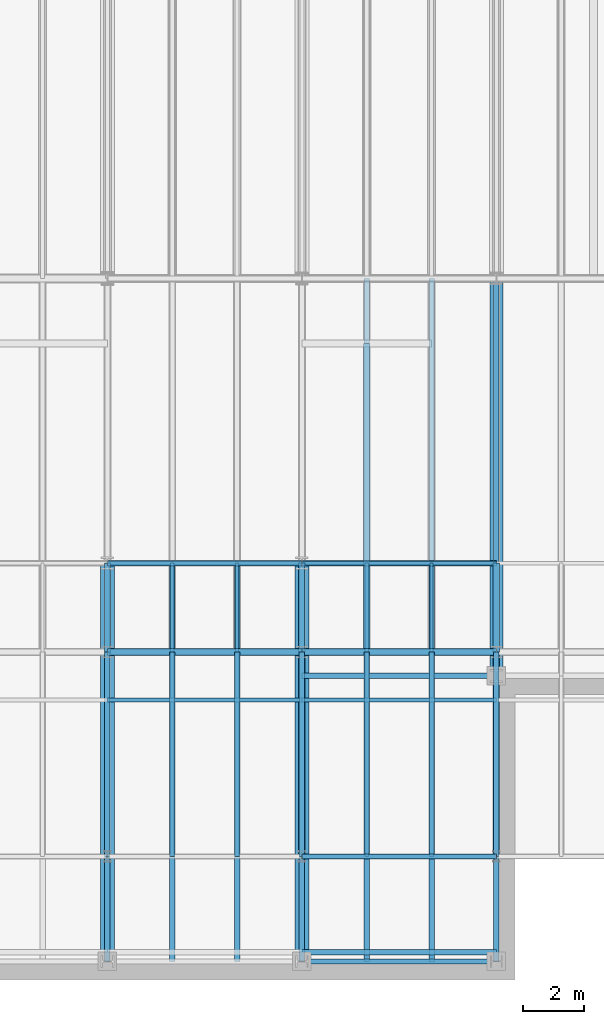
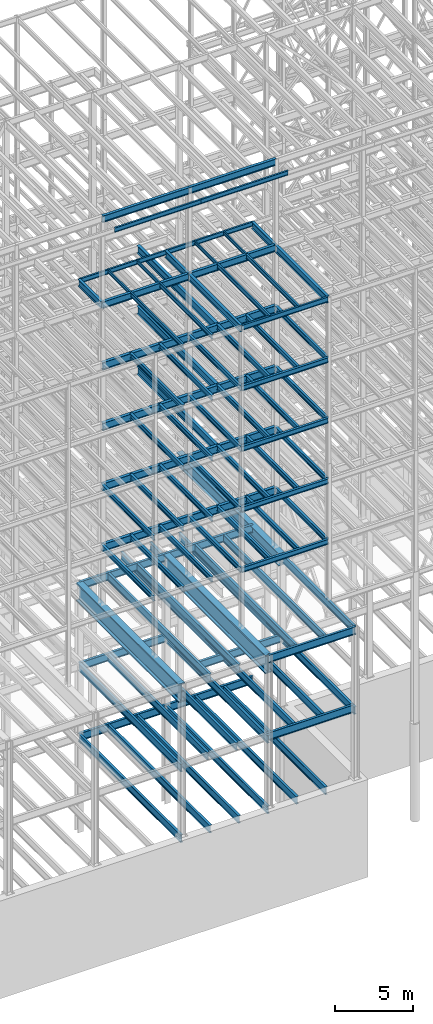
# One storey, part 129 of 150: 95 beams.
"""IFC2X3 building model written with IfcOpenShell, lengths in millimetres."""

from ifc_helpers import new_model, si_unit, frame, origin_with_axes, origin_2d_with_axis, place, context, subcontext, project, spatial, i_section, extrude, material, type_object, element, save


model = new_model("IFC2X3")

# Units and contexts
model_context = context("Model", 3, precision=1e-05, world=origin_with_axes())
body_context = subcontext(model_context, "Body", "Model", "MODEL_VIEW")
ifc_project = project(units=[si_unit("LENGTHUNIT", "METRE", prefix="MILLI"), si_unit("AREAUNIT", "SQUARE_METRE"), si_unit("VOLUMEUNIT", "CUBIC_METRE"), si_unit("MASSUNIT", "GRAM", prefix="KILO"), si_unit("TIMEUNIT", "SECOND"), si_unit("PLANEANGLEUNIT", "RADIAN"), si_unit("SOLIDANGLEUNIT", "STERADIAN"), si_unit("THERMODYNAMICTEMPERATUREUNIT", "DEGREE_CELSIUS"), si_unit("LUMINOUSINTENSITYUNIT", "LUMEN")], contexts=[model_context])

# Site, building, storey
site_placement = place(None, origin_with_axes())
site = spatial("IfcSite", under=ifc_project, at=site_placement, CompositionType="ELEMENT")
building_placement = place(site_placement, origin_with_axes())
building = spatial("IfcBuilding", under=site, at=building_placement, Name="Undefined", CompositionType="ELEMENT")
storey_placement = place(building_placement, origin_with_axes())
storey = spatial("IfcBuildingStorey", under=building, at=storey_placement, Name="Undefined", CompositionType="ELEMENT", Elevation=0.0)

# Beams
ifc_material = material(Name="STEEL/A992")
beam_type_1 = type_object("IfcBeamType", Name="W16X31", PredefinedType="NOTDEFINED")
beam_1_placement = place(storey_placement, frame((37388.8, 3454.4, 59005.7875), z_axis=(0.0, 0.0, 1.0), x_axis=(1.0, 0.0, 0.0)))
element("IfcBeam", 1, at=beam_1_placement, inside=storey, type_object=beam_type_1, material=ifc_material, Name="BEAM", ObjectType="W16X31", context=body_context, shape_type="SweptSolid", body=[
    extrude(i_section(OverallWidth=140.462, OverallDepth=403.225, WebThickness=6.3499, FlangeThickness=11.176, FilletRadius=17.399, at=origin_2d_with_axis()), frame((6400.80000000001, 0.0, 0.0), z_axis=(-1.0, 0.0, 0.0), x_axis=(0.0, -1.0, 0.0)), (0.0, 0.0, 1.0), 6400.8),
])
beam_type_2 = type_object("IfcBeamType", Name="W24X68", PredefinedType="NOTDEFINED")
beam_2_placement = place(storey_placement, frame((39522.4, 10185.4, 54181.375), z_axis=(0.0, 0.0, 1.0), x_axis=(0.0, 1.0, 0.0)))
element("IfcBeam", 2, at=beam_2_placement, inside=storey, type_object=beam_type_2, material=ifc_material, Name="BEAM", ObjectType="W24X68", context=body_context, shape_type="SweptSolid", body=[
    extrude(i_section(OverallWidth=227.838, OverallDepth=603.25, WebThickness=11.1125, FlangeThickness=14.859, FilletRadius=23.2409, at=origin_2d_with_axis()), frame((10159.9979680001, 0.0, 0.0), z_axis=(-1.0, 0.0, 0.0), x_axis=(0.0, -1.0, 0.0)), (0.0, 0.0, 1.0), 10159.9979680001),
])
for number, where, z_axis, x_axis, name in (
    (3, (37388.8, 10185.4, 54181.375), (0.0, 0.0, 1.0), (1.0, 0.0, 0.0), "BEAM"),
    (4, (30988.0, 10185.4, 54181.375), (0.0, 0.0, 1.0), (1.0, 0.0, 0.0), "BEAM"),
):
    element("IfcBeam", number, at=place(storey_placement, frame(where, z_axis=z_axis, x_axis=x_axis)), inside=storey, type_object=beam_type_2, material=ifc_material, Name=name, ObjectType="W24X68", context=body_context, shape_type="SweptSolid", body=[
        extrude(i_section(OverallWidth=227.838, OverallDepth=603.25, WebThickness=11.1125, FlangeThickness=14.859, FilletRadius=23.2409, at=origin_2d_with_axis()), frame((6400.79935992001, 0.0, 0.0), z_axis=(-1.0, 0.0, 0.0), x_axis=(0.0, -1.0, 0.0)), (0.0, 0.0, 1.0), 6400.79935992),
    ])
beam_3_placement = place(storey_placement, frame((39522.4, 10185.4, 49456.975), z_axis=(0.0, 0.0, 1.0), x_axis=(0.0, 1.0, 0.0)))
element("IfcBeam", 5, at=beam_3_placement, inside=storey, type_object=beam_type_2, material=ifc_material, Name="BEAM", ObjectType="W24X68", context=body_context, shape_type="SweptSolid", body=[
    extrude(i_section(OverallWidth=227.838, OverallDepth=603.25, WebThickness=11.1125, FlangeThickness=14.859, FilletRadius=23.2409, at=origin_2d_with_axis()), frame((10159.998984, 0.0, 0.0), z_axis=(-1.0, 0.0, 0.0), x_axis=(0.0, -1.0, 0.0)), (0.0, 0.0, 1.0), 10159.998984),
])
for number, where, z_axis, x_axis, name in (
    (6, (37388.8, 10185.4, 49456.975), (0.0, 0.0, 1.0), (1.0, 0.0, 0.0), "BEAM"),
    (7, (30988.0, 10185.4, 49456.975), (0.0, 0.0, 1.0), (1.0, 0.0, 0.0), "BEAM"),
):
    element("IfcBeam", number, at=place(storey_placement, frame(where, z_axis=z_axis, x_axis=x_axis)), inside=storey, type_object=beam_type_2, material=ifc_material, Name=name, ObjectType="W24X68", context=body_context, shape_type="SweptSolid", body=[
        extrude(i_section(OverallWidth=227.838, OverallDepth=603.25, WebThickness=11.1125, FlangeThickness=14.859, FilletRadius=23.2409, at=origin_2d_with_axis()), frame((6400.79935992001, 0.0, 0.0), z_axis=(-1.0, 0.0, 0.0), x_axis=(0.0, -1.0, 0.0)), (0.0, 0.0, 1.0), 6400.79935992),
    ])
beam_4_placement = place(storey_placement, frame((39522.4, 10185.4, 44732.575), z_axis=(0.0, 0.0, 1.0), x_axis=(0.0, 1.0, 0.0)))
element("IfcBeam", 8, at=beam_4_placement, inside=storey, type_object=beam_type_2, material=ifc_material, Name="BEAM", ObjectType="W24X68", context=body_context, shape_type="SweptSolid", body=[
    extrude(i_section(OverallWidth=227.838, OverallDepth=603.25, WebThickness=11.1125, FlangeThickness=14.859, FilletRadius=23.2409, at=origin_2d_with_axis()), frame((10160.0, 0.0, 0.0), z_axis=(-1.0, 0.0, 0.0), x_axis=(0.0, -1.0, 0.0)), (0.0, 0.0, 1.0), 10160.0),
])
for number, where, z_axis, x_axis, name in (
    (9, (37388.8, 10185.4, 44732.575), (0.0, 0.0, 1.0), (1.0, 0.0, 0.0), "BEAM"),
    (10, (30988.0, 10185.4, 44732.575), (0.0, 0.0, 1.0), (1.0, 0.0, 0.0), "BEAM"),
):
    element("IfcBeam", number, at=place(storey_placement, frame(where, z_axis=z_axis, x_axis=x_axis)), inside=storey, type_object=beam_type_2, material=ifc_material, Name=name, ObjectType="W24X68", context=body_context, shape_type="SweptSolid", body=[
        extrude(i_section(OverallWidth=227.838, OverallDepth=603.25, WebThickness=11.1125, FlangeThickness=14.859, FilletRadius=23.2409, at=origin_2d_with_axis()), frame((6400.79935992001, 0.0, 0.0), z_axis=(-1.0, 0.0, 0.0), x_axis=(0.0, -1.0, 0.0)), (0.0, 0.0, 1.0), 6400.79935992),
    ])
for number, where, z_axis, x_axis, name in (
    (11, (37388.8, 10185.4, 40008.175), (0.0, 0.0, 1.0), (1.0, 0.0, 0.0), "BEAM"),
    (12, (30988.0, 10185.4, 40008.175), (0.0, 0.0, 1.0), (1.0, 0.0, 0.0), "BEAM"),
):
    element("IfcBeam", number, at=place(storey_placement, frame(where, z_axis=z_axis, x_axis=x_axis)), inside=storey, type_object=beam_type_2, material=ifc_material, Name=name, ObjectType="W24X68", context=body_context, shape_type="SweptSolid", body=[
        extrude(i_section(OverallWidth=227.838, OverallDepth=603.25, WebThickness=11.1125, FlangeThickness=14.859, FilletRadius=23.2409, at=origin_2d_with_axis()), frame((6400.80000000001, 0.0, 0.0), z_axis=(-1.0, 0.0, 0.0), x_axis=(0.0, -1.0, 0.0)), (0.0, 0.0, 1.0), 6400.8),
    ])
beam_type_3 = type_object("IfcBeamType", Name="W14X22", PredefinedType="NOTDEFINED")
beam_5_placement = place(storey_placement, frame((37388.8, 8610.6, 65738.375), z_axis=(0.0, 0.0, 1.0), x_axis=(1.0, 0.0, 0.0)))
element("IfcBeam", 13, at=beam_5_placement, inside=storey, type_object=beam_type_3, material=ifc_material, Name="BEAM", ObjectType="W14X22", context=body_context, shape_type="SweptSolid", body=[
    extrude(i_section(OverallWidth=127.0, OverallDepth=349.25, WebThickness=6.3499, FlangeThickness=8.509, FilletRadius=18.4785, at=origin_2d_with_axis()), frame((6400.80000000001, 0.0, 0.0), z_axis=(-1.0, 0.0, 0.0), x_axis=(0.0, -1.0, 0.0)), (0.0, 0.0, 1.0), 6400.8),
])
beam_6_placement = place(storey_placement, frame((30988.0, 8610.6, 65738.375), z_axis=(0.0, 0.0, 1.0), x_axis=(1.0, 0.0, 0.0)))
element("IfcBeam", 14, at=beam_6_placement, inside=storey, type_object=beam_type_3, material=ifc_material, Name="BEAM", ObjectType="W14X22", context=body_context, shape_type="SweptSolid", body=[
    extrude(i_section(OverallWidth=127.0, OverallDepth=349.25, WebThickness=6.3499, FlangeThickness=8.509, FilletRadius=18.4785, at=origin_2d_with_axis()), frame((6400.80000000001, 0.0, 0.0), z_axis=(-1.0, 0.0, 0.0), x_axis=(0.0, -1.0, 0.0)), (0.0, 0.0, 1.0), 6400.80000000001),
])
beam_7_placement = place(storey_placement, frame((37388.8, 13106.4, 59032.775), z_axis=(0.0, 0.0, 1.0), x_axis=(1.0, 0.0, 0.0)))
element("IfcBeam", 15, at=beam_7_placement, inside=storey, type_object=beam_type_3, material=ifc_material, Name="BEAM", ObjectType="W14X22", context=body_context, shape_type="SweptSolid", body=[
    extrude(i_section(OverallWidth=127.0, OverallDepth=349.25, WebThickness=6.3499, FlangeThickness=8.509, FilletRadius=18.4785, at=origin_2d_with_axis()), frame((6400.80000000001, 0.0, 0.0), z_axis=(-1.0, 0.0, 0.0), x_axis=(0.0, -1.0, 0.0)), (0.0, 0.0, 1.0), 6400.8),
])
for number, where, z_axis, x_axis, name in (
    (16, (41656.0, 3454.4, 59032.775), (0.0, 0.0, 1.0), (0.0, 1.0, 0.0), "BEAM"),
    (17, (39522.4, 3454.4, 59032.775), (0.0, 0.0, 1.0), (0.0, 1.0, 0.0), "BEAM"),
):
    element("IfcBeam", number, at=place(storey_placement, frame(where, z_axis=z_axis, x_axis=x_axis)), inside=storey, type_object=beam_type_3, material=ifc_material, Name=name, ObjectType="W14X22", context=body_context, shape_type="SweptSolid", body=[
        extrude(i_section(OverallWidth=127.0, OverallDepth=349.25, WebThickness=6.3499, FlangeThickness=8.509, FilletRadius=18.4785, at=origin_2d_with_axis()), frame((6731.0, 0.0, 0.0), z_axis=(-1.0, 0.0, 0.0), x_axis=(0.0, -1.0, 0.0)), (0.0, 0.0, 1.0), 6731.0),
    ])
beam_8_placement = place(storey_placement, frame((30988.0, 13106.4, 59032.775), z_axis=(0.0, 0.0, 1.0), x_axis=(1.0, 0.0, 0.0)))
element("IfcBeam", 18, at=beam_8_placement, inside=storey, type_object=beam_type_3, material=ifc_material, Name="BEAM", ObjectType="W14X22", context=body_context, shape_type="SweptSolid", body=[
    extrude(i_section(OverallWidth=127.0, OverallDepth=349.25, WebThickness=6.3499, FlangeThickness=8.509, FilletRadius=18.4785, at=origin_2d_with_axis()), frame((6400.80000000001, 0.0, 0.0), z_axis=(-1.0, 0.0, 0.0), x_axis=(0.0, -1.0, 0.0)), (0.0, 0.0, 1.0), 6400.80000000001),
])
for number, where, z_axis, x_axis, name in (
    (19, (35255.2, 3454.4, 59032.775), (0.0, 0.0, 1.0), (0.0, 1.0, 0.0), "BEAM"),
    (20, (33121.6, 3454.4, 59032.775), (0.0, 0.0, 1.0), (0.0, 1.0, 0.0), "BEAM"),
):
    element("IfcBeam", number, at=place(storey_placement, frame(where, z_axis=z_axis, x_axis=x_axis)), inside=storey, type_object=beam_type_3, material=ifc_material, Name=name, ObjectType="W14X22", context=body_context, shape_type="SweptSolid", body=[
        extrude(i_section(OverallWidth=127.0, OverallDepth=349.25, WebThickness=6.3499, FlangeThickness=8.509, FilletRadius=18.4785, at=origin_2d_with_axis()), frame((6731.0, 0.0, 0.0), z_axis=(-1.0, 0.0, 0.0), x_axis=(0.0, -1.0, 0.0)), (0.0, 0.0, 1.0), 6731.0),
    ])
beam_type_4 = type_object("IfcBeamType", Name="W21X55", PredefinedType="NOTDEFINED")
beam_9_placement = place(storey_placement, frame((37388.8, 10185.4, 65649.475), z_axis=(0.0, 0.0, 1.0), x_axis=(1.0, 0.0, 0.0)))
element("IfcBeam", 21, at=beam_9_placement, inside=storey, type_object=beam_type_4, material=ifc_material, Name="BEAM", ObjectType="W21X55", context=body_context, shape_type="SweptSolid", body=[
    extrude(i_section(OverallWidth=208.788, OverallDepth=527.05, WebThickness=9.5, FlangeThickness=13.2588, FilletRadius=16.8624, at=origin_2d_with_axis()), frame((6400.80000000001, 0.0, 0.0), z_axis=(-1.0, 0.0, 0.0), x_axis=(0.0, -1.0, 0.0)), (0.0, 0.0, 1.0), 6400.8),
])
beam_10_placement = place(storey_placement, frame((30988.0, 10185.4, 65649.475), z_axis=(0.0, 0.0, 1.0), x_axis=(1.0, 0.0, 0.0)))
element("IfcBeam", 22, at=beam_10_placement, inside=storey, type_object=beam_type_4, material=ifc_material, Name="BEAM", ObjectType="W21X55", context=body_context, shape_type="SweptSolid", body=[
    extrude(i_section(OverallWidth=208.788, OverallDepth=527.05, WebThickness=9.5, FlangeThickness=13.2588, FilletRadius=16.8624, at=origin_2d_with_axis()), frame((6400.80000000001, 0.0, 0.0), z_axis=(-1.0, 0.0, 0.0), x_axis=(0.0, -1.0, 0.0)), (0.0, 0.0, 1.0), 6400.80000000001),
])
beam_11_placement = place(storey_placement, frame((43789.6, 10185.4, 58943.875), z_axis=(0.0, 0.0, 1.0), x_axis=(0.0, 1.0, 0.0)))
element("IfcBeam", 23, at=beam_11_placement, inside=storey, type_object=beam_type_4, material=ifc_material, Name="BEAM", ObjectType="W21X55", context=body_context, shape_type="SweptSolid", body=[
    extrude(i_section(OverallWidth=208.788, OverallDepth=527.05, WebThickness=9.5, FlangeThickness=13.2588, FilletRadius=16.8624, at=origin_2d_with_axis()), frame((2921.0, 0.0, 0.0), z_axis=(-1.0, 0.0, 0.0), x_axis=(0.0, -1.0, 0.0)), (0.0, 0.0, 1.0), 2921.0),
])
beam_12_placement = place(storey_placement, frame((43789.6, 3454.4, 58943.875), z_axis=(0.0, 0.0, 1.0), x_axis=(0.0, 1.0, 0.0)))
element("IfcBeam", 24, at=beam_12_placement, inside=storey, type_object=beam_type_4, material=ifc_material, Name="BEAM", ObjectType="W21X55", context=body_context, shape_type="SweptSolid", body=[
    extrude(i_section(OverallWidth=208.788, OverallDepth=527.05, WebThickness=9.5, FlangeThickness=13.2588, FilletRadius=16.8624, at=origin_2d_with_axis()), frame((6731.0, 0.0, 0.0), z_axis=(-1.0, 0.0, 0.0), x_axis=(0.0, -1.0, 0.0)), (0.0, 0.0, 1.0), 6731.0),
])
beam_13_placement = place(storey_placement, frame((37388.8, 10185.4, 58943.875), z_axis=(0.0, 0.0, 1.0), x_axis=(1.0, 0.0, 0.0)))
element("IfcBeam", 25, at=beam_13_placement, inside=storey, type_object=beam_type_4, material=ifc_material, Name="BEAM", ObjectType="W21X55", context=body_context, shape_type="SweptSolid", body=[
    extrude(i_section(OverallWidth=208.788, OverallDepth=527.05, WebThickness=9.5, FlangeThickness=13.2588, FilletRadius=16.8624, at=origin_2d_with_axis()), frame((6400.80000000001, 0.0, 0.0), z_axis=(-1.0, 0.0, 0.0), x_axis=(0.0, -1.0, 0.0)), (0.0, 0.0, 1.0), 6400.8),
])
beam_14_placement = place(storey_placement, frame((37388.8, 10185.4, 58943.875), z_axis=(0.0, 0.0, 1.0), x_axis=(0.0, 1.0, 0.0)))
element("IfcBeam", 26, at=beam_14_placement, inside=storey, type_object=beam_type_4, material=ifc_material, Name="BEAM", ObjectType="W21X55", context=body_context, shape_type="SweptSolid", body=[
    extrude(i_section(OverallWidth=208.788, OverallDepth=527.05, WebThickness=9.5, FlangeThickness=13.2588, FilletRadius=16.8624, at=origin_2d_with_axis()), frame((2921.0, 0.0, 0.0), z_axis=(-1.0, 0.0, 0.0), x_axis=(0.0, -1.0, 0.0)), (0.0, 0.0, 1.0), 2921.0),
])
beam_15_placement = place(storey_placement, frame((37388.8, 3454.4, 58943.875), z_axis=(0.0, 0.0, 1.0), x_axis=(0.0, 1.0, 0.0)))
element("IfcBeam", 27, at=beam_15_placement, inside=storey, type_object=beam_type_4, material=ifc_material, Name="BEAM", ObjectType="W21X55", context=body_context, shape_type="SweptSolid", body=[
    extrude(i_section(OverallWidth=208.788, OverallDepth=527.05, WebThickness=9.5, FlangeThickness=13.2588, FilletRadius=16.8624, at=origin_2d_with_axis()), frame((6731.0, 0.0, 0.0), z_axis=(-1.0, 0.0, 0.0), x_axis=(0.0, -1.0, 0.0)), (0.0, 0.0, 1.0), 6731.0),
])
beam_16_placement = place(storey_placement, frame((30988.0, 10185.4, 58943.875), z_axis=(0.0, 0.0, 1.0), x_axis=(1.0, 0.0, 0.0)))
element("IfcBeam", 28, at=beam_16_placement, inside=storey, type_object=beam_type_4, material=ifc_material, Name="BEAM", ObjectType="W21X55", context=body_context, shape_type="SweptSolid", body=[
    extrude(i_section(OverallWidth=208.788, OverallDepth=527.05, WebThickness=9.5, FlangeThickness=13.2588, FilletRadius=16.8624, at=origin_2d_with_axis()), frame((6400.80000000001, 0.0, 0.0), z_axis=(-1.0, 0.0, 0.0), x_axis=(0.0, -1.0, 0.0)), (0.0, 0.0, 1.0), 6400.80000000001),
])
beam_17_placement = place(storey_placement, frame((30988.0, 10185.4, 58943.875), z_axis=(0.0, 0.0, 1.0), x_axis=(0.0, 1.0, 0.0)))
element("IfcBeam", 29, at=beam_17_placement, inside=storey, type_object=beam_type_4, material=ifc_material, Name="BEAM", ObjectType="W21X55", context=body_context, shape_type="SweptSolid", body=[
    extrude(i_section(OverallWidth=208.788, OverallDepth=527.05, WebThickness=9.5, FlangeThickness=13.2588, FilletRadius=16.8624, at=origin_2d_with_axis()), frame((2921.0, 0.0, 0.0), z_axis=(-1.0, 0.0, 0.0), x_axis=(0.0, -1.0, 0.0)), (0.0, 0.0, 1.0), 2921.0),
])
beam_type_5 = type_object("IfcBeamType", Name="W10X15", PredefinedType="NOTDEFINED")
for number, where, z_axis, x_axis, name in (
    (30, (41656.0, 10185.4, 59080.4), (0.0, 0.0, 1.0), (0.0, 1.0, 0.0), "BEAM"),
    (31, (39522.4, 10185.4, 59080.4), (0.0, 0.0, 1.0), (0.0, 1.0, 0.0), "BEAM"),
    (32, (35255.2, 10185.4, 59080.4), (0.0, 0.0, 1.0), (0.0, 1.0, 0.0), "BEAM"),
    (33, (33121.6, 10185.4, 59080.4), (0.0, 0.0, 1.0), (0.0, 1.0, 0.0), "BEAM"),
):
    element("IfcBeam", number, at=place(storey_placement, frame(where, z_axis=z_axis, x_axis=x_axis)), inside=storey, type_object=beam_type_5, material=ifc_material, Name=name, ObjectType="W10X15", context=body_context, shape_type="SweptSolid", body=[
        extrude(i_section(OverallWidth=101.6, OverallDepth=254.0, WebThickness=6.3499, FlangeThickness=6.858, FilletRadius=13.7795, at=origin_2d_with_axis()), frame((2921.0, 0.0, 0.0), z_axis=(-1.0, 0.0, 0.0), x_axis=(0.0, -1.0, 0.0)), (0.0, 0.0, 1.0), 2921.0),
    ])
beam_type_6 = type_object("IfcBeamType", Name="W16X36", PredefinedType="NOTDEFINED")
beam_18_placement = place(storey_placement, frame((37388.8, 3454.4, 54281.3875), z_axis=(0.0, 0.0, 1.0), x_axis=(1.0, 0.0, 0.0)))
element("IfcBeam", 34, at=beam_18_placement, inside=storey, type_object=beam_type_6, material=ifc_material, Name="BEAM", ObjectType="W16X36", context=body_context, shape_type="SweptSolid", body=[
    extrude(i_section(OverallWidth=177.8, OverallDepth=403.225, WebThickness=7.9375, FlangeThickness=10.922, FilletRadius=17.6529, at=origin_2d_with_axis()), frame((6400.80000000001, 0.0, 0.0), z_axis=(-1.0, 0.0, 0.0), x_axis=(0.0, -1.0, 0.0)), (0.0, 0.0, 1.0), 6400.8),
])
for number, where, z_axis, x_axis, name in (
    (35, (43789.6, 3454.4, 54281.3875), (0.0, 0.0, 1.0), (0.0, 1.0, 0.0), "BEAM"),
    (36, (41656.0, 3454.4, 54281.3875), (0.0, 0.0, 1.0), (0.0, 1.0, 0.0), "BEAM"),
    (37, (39522.4, 3454.4, 54281.3875), (0.0, 0.0, 1.0), (0.0, 1.0, 0.0), "BEAM"),
    (38, (37388.8, 3454.4, 54281.3875), (0.0, 0.0, 1.0), (0.0, 1.0, 0.0), "BEAM"),
    (39, (35255.2, 3454.4, 54281.3875), (0.0, 0.0, 1.0), (0.0, 1.0, 0.0), "BEAM"),
    (40, (33121.6, 3454.4, 54281.3875), (0.0, 0.0, 1.0), (0.0, 1.0, 0.0), "BEAM"),
):
    element("IfcBeam", number, at=place(storey_placement, frame(where, z_axis=z_axis, x_axis=x_axis)), inside=storey, type_object=beam_type_6, material=ifc_material, Name=name, ObjectType="W16X36", context=body_context, shape_type="SweptSolid", body=[
        extrude(i_section(OverallWidth=177.8, OverallDepth=403.225, WebThickness=7.9375, FlangeThickness=10.922, FilletRadius=17.6529, at=origin_2d_with_axis()), frame((6731.0, 0.0, 0.0), z_axis=(-1.0, 0.0, 0.0), x_axis=(0.0, -1.0, 0.0)), (0.0, 0.0, 1.0), 6731.0),
    ])
beam_19_placement = place(storey_placement, frame((37388.8, 3454.4, 49556.9875), z_axis=(0.0, 0.0, 1.0), x_axis=(1.0, 0.0, 0.0)))
element("IfcBeam", 41, at=beam_19_placement, inside=storey, type_object=beam_type_6, material=ifc_material, Name="BEAM", ObjectType="W16X36", context=body_context, shape_type="SweptSolid", body=[
    extrude(i_section(OverallWidth=177.8, OverallDepth=403.225, WebThickness=7.9375, FlangeThickness=10.922, FilletRadius=17.6529, at=origin_2d_with_axis()), frame((6400.80000000001, 0.0, 0.0), z_axis=(-1.0, 0.0, 0.0), x_axis=(0.0, -1.0, 0.0)), (0.0, 0.0, 1.0), 6400.8),
])
for number, where, z_axis, x_axis, name in (
    (42, (43789.6, 3454.4, 49556.9875), (0.0, 0.0, 1.0), (0.0, 1.0, 0.0), "BEAM"),
    (43, (41656.0, 3454.4, 49556.9875), (0.0, 0.0, 1.0), (0.0, 1.0, 0.0), "BEAM"),
    (44, (39522.4, 3454.4, 49556.9875), (0.0, 0.0, 1.0), (0.0, 1.0, 0.0), "BEAM"),
    (45, (37388.8, 3454.4, 49556.9875), (0.0, 0.0, 1.0), (0.0, 1.0, 0.0), "BEAM"),
    (46, (35255.2, 3454.4, 49556.9875), (0.0, 0.0, 1.0), (0.0, 1.0, 0.0), "BEAM"),
    (47, (33121.6, 3454.4, 49556.9875), (0.0, 0.0, 1.0), (0.0, 1.0, 0.0), "BEAM"),
):
    element("IfcBeam", number, at=place(storey_placement, frame(where, z_axis=z_axis, x_axis=x_axis)), inside=storey, type_object=beam_type_6, material=ifc_material, Name=name, ObjectType="W16X36", context=body_context, shape_type="SweptSolid", body=[
        extrude(i_section(OverallWidth=177.8, OverallDepth=403.225, WebThickness=7.9375, FlangeThickness=10.922, FilletRadius=17.6529, at=origin_2d_with_axis()), frame((6731.0, 0.0, 0.0), z_axis=(-1.0, 0.0, 0.0), x_axis=(0.0, -1.0, 0.0)), (0.0, 0.0, 1.0), 6731.0),
    ])
beam_20_placement = place(storey_placement, frame((37388.8, 3454.4, 44832.5875), z_axis=(0.0, 0.0, 1.0), x_axis=(1.0, 0.0, 0.0)))
element("IfcBeam", 48, at=beam_20_placement, inside=storey, type_object=beam_type_6, material=ifc_material, Name="BEAM", ObjectType="W16X36", context=body_context, shape_type="SweptSolid", body=[
    extrude(i_section(OverallWidth=177.8, OverallDepth=403.225, WebThickness=7.9375, FlangeThickness=10.922, FilletRadius=17.6529, at=origin_2d_with_axis()), frame((6400.80000000001, 0.0, 0.0), z_axis=(-1.0, 0.0, 0.0), x_axis=(0.0, -1.0, 0.0)), (0.0, 0.0, 1.0), 6400.8),
])
for number, where, z_axis, x_axis, name in (
    (49, (43789.6, 3454.4, 44832.5875), (0.0, 0.0, 1.0), (0.0, 1.0, 0.0), "BEAM"),
    (50, (41656.0, 3454.4, 44832.5875), (0.0, 0.0, 1.0), (0.0, 1.0, 0.0), "BEAM"),
    (51, (39522.4, 3454.4, 44832.5875), (0.0, 0.0, 1.0), (0.0, 1.0, 0.0), "BEAM"),
    (52, (37388.8, 3454.4, 44832.5875), (0.0, 0.0, 1.0), (0.0, 1.0, 0.0), "BEAM"),
    (53, (35255.2, 3454.4, 44832.5875), (0.0, 0.0, 1.0), (0.0, 1.0, 0.0), "BEAM"),
    (54, (33121.6, 3454.4, 44832.5875), (0.0, 0.0, 1.0), (0.0, 1.0, 0.0), "BEAM"),
    (55, (30988.0, 3454.4, 44832.5875), (0.0, 0.0, 1.0), (0.0, 1.0, 0.0), "BEAM"),
):
    element("IfcBeam", number, at=place(storey_placement, frame(where, z_axis=z_axis, x_axis=x_axis)), inside=storey, type_object=beam_type_6, material=ifc_material, Name=name, ObjectType="W16X36", context=body_context, shape_type="SweptSolid", body=[
        extrude(i_section(OverallWidth=177.8, OverallDepth=403.225, WebThickness=7.9375, FlangeThickness=10.922, FilletRadius=17.6529, at=origin_2d_with_axis()), frame((6731.0, 0.0, 0.0), z_axis=(-1.0, 0.0, 0.0), x_axis=(0.0, -1.0, 0.0)), (0.0, 0.0, 1.0), 6731.0),
    ])
beam_21_placement = place(storey_placement, frame((37388.8, 3454.4, 40108.1875), z_axis=(0.0, 0.0, 1.0), x_axis=(1.0, 0.0, 0.0)))
element("IfcBeam", 56, at=beam_21_placement, inside=storey, type_object=beam_type_6, material=ifc_material, Name="BEAM", ObjectType="W16X36", context=body_context, shape_type="SweptSolid", body=[
    extrude(i_section(OverallWidth=177.8, OverallDepth=403.225, WebThickness=7.9375, FlangeThickness=10.922, FilletRadius=17.6529, at=origin_2d_with_axis()), frame((6400.80000000001, 0.0, 0.0), z_axis=(-1.0, 0.0, 0.0), x_axis=(0.0, -1.0, 0.0)), (0.0, 0.0, 1.0), 6400.8),
])
for number, where, z_axis, x_axis, name in (
    (57, (43789.6, 3454.4, 40108.1875), (0.0, 0.0, 1.0), (0.0, 1.0, 0.0), "BEAM"),
    (58, (41656.0, 3454.4, 40108.1875), (0.0, 0.0, 1.0), (0.0, 1.0, 0.0), "BEAM"),
    (59, (39522.4, 3454.4, 40108.1875), (0.0, 0.0, 1.0), (0.0, 1.0, 0.0), "BEAM"),
    (60, (37388.8, 3454.4, 40108.1875), (0.0, 0.0, 1.0), (0.0, 1.0, 0.0), "BEAM"),
    (61, (35255.2, 3454.4, 40108.1875), (0.0, 0.0, 1.0), (0.0, 1.0, 0.0), "BEAM"),
    (62, (33121.6, 3454.4, 40108.1875), (0.0, 0.0, 1.0), (0.0, 1.0, 0.0), "BEAM"),
    (63, (30988.0, 3454.4, 40108.1875), (0.0, 0.0, 1.0), (0.0, 1.0, 0.0), "BEAM"),
):
    element("IfcBeam", number, at=place(storey_placement, frame(where, z_axis=z_axis, x_axis=x_axis)), inside=storey, type_object=beam_type_6, material=ifc_material, Name=name, ObjectType="W16X36", context=body_context, shape_type="SweptSolid", body=[
        extrude(i_section(OverallWidth=177.8, OverallDepth=403.225, WebThickness=7.9375, FlangeThickness=10.922, FilletRadius=17.6529, at=origin_2d_with_axis()), frame((6731.0, 0.0, 0.0), z_axis=(-1.0, 0.0, 0.0), x_axis=(0.0, -1.0, 0.0)), (0.0, 0.0, 1.0), 6731.0),
    ])
beam_type_7 = type_object("IfcBeamType", Name="W24X62", PredefinedType="NOTDEFINED")
beam_22_placement = place(storey_placement, frame((37388.8, 0.0, 35283.775), z_axis=(0.0, 0.0, 1.0), x_axis=(1.0, 0.0, 0.0)))
element("IfcBeam", 64, at=beam_22_placement, inside=storey, type_object=beam_type_7, material=ifc_material, Name="BEAM", ObjectType="W24X62", context=body_context, shape_type="SweptSolid", body=[
    extrude(i_section(OverallWidth=177.8, OverallDepth=603.25, WebThickness=11.1125, FlangeThickness=14.986, FilletRadius=23.114, at=origin_2d_with_axis()), frame((6400.80000000001, 0.0, 0.0), z_axis=(-1.0, 0.0, 0.0), x_axis=(0.0, -1.0, 0.0)), (0.0, 0.0, 1.0), 6400.8),
])
beam_23_placement = place(storey_placement, frame((43789.6, 0.0, 35283.775), z_axis=(0.0, 0.0, 1.0), x_axis=(0.0, 1.0, 0.0)))
element("IfcBeam", 65, at=beam_23_placement, inside=storey, type_object=beam_type_7, material=ifc_material, Name="BEAM", ObjectType="W24X62", context=body_context, shape_type="SweptSolid", body=[
    extrude(i_section(OverallWidth=177.8, OverallDepth=603.25, WebThickness=11.1125, FlangeThickness=14.986, FilletRadius=23.114, at=origin_2d_with_axis()), frame((9398.0, 0.0, 0.0), z_axis=(-1.0, 0.0, 0.0), x_axis=(0.0, -1.0, 0.0)), (0.0, 0.0, 1.0), 9398.0),
])
for number, where, z_axis, x_axis, name in (
    (66, (41656.0, 0.0, 35283.775), (0.0, 0.0, 1.0), (0.0, 1.0, 0.0), "BEAM"),
    (67, (39522.4, 0.0, 35283.775), (0.0, 0.0, 1.0), (0.0, 1.0, 0.0), "BEAM"),
    (68, (35255.2, 0.0, 35283.775), (0.0, 0.0, 1.0), (0.0, 1.0, 0.0), "BEAM"),
    (69, (33121.6, 0.0, 35283.775), (0.0, 0.0, 1.0), (0.0, 1.0, 0.0), "BEAM"),
):
    element("IfcBeam", number, at=place(storey_placement, frame(where, z_axis=z_axis, x_axis=x_axis)), inside=storey, type_object=beam_type_7, material=ifc_material, Name=name, ObjectType="W24X62", context=body_context, shape_type="SweptSolid", body=[
        extrude(i_section(OverallWidth=177.8, OverallDepth=603.25, WebThickness=11.1125, FlangeThickness=14.986, FilletRadius=23.114, at=origin_2d_with_axis()), frame((13106.4, 0.0, 0.0), z_axis=(-1.0, 0.0, 0.0), x_axis=(0.0, -1.0, 0.0)), (0.0, 0.0, 1.0), 13106.4),
    ])
for number, where, z_axis, x_axis, name in (
    (70, (37388.8, 13106.4, 35283.775), (0.0, 0.0, 1.0), (1.0, 0.0, 0.0), "BEAM"),
    (71, (30988.0, 13106.4, 35283.775), (0.0, 0.0, 1.0), (1.0, 0.0, 0.0), "BEAM"),
    (72, (30988.0, 13106.4, 28984.575), (0.0, 0.0, 1.0), (1.0, 0.0, 0.0), "BEAM"),
):
    element("IfcBeam", number, at=place(storey_placement, frame(where, z_axis=z_axis, x_axis=x_axis)), inside=storey, type_object=beam_type_7, material=ifc_material, Name=name, ObjectType="W24X62", context=body_context, shape_type="SweptSolid", body=[
        extrude(i_section(OverallWidth=177.8, OverallDepth=603.25, WebThickness=11.1125, FlangeThickness=14.986, FilletRadius=23.114, at=origin_2d_with_axis()), frame((6400.80000000001, 0.0, 0.0), z_axis=(-1.0, 0.0, 0.0), x_axis=(0.0, -1.0, 0.0)), (0.0, 0.0, 1.0), 6400.8),
    ])
for number, where, z_axis, x_axis, name in (
    (73, (43789.6, 9398.0, 28984.575), (0.0, 0.0, 1.0), (0.0, 1.0, 0.0), "BEAM"),
    (74, (41656.0, 9398.0, 28984.575), (0.0, 0.0, 1.0), (0.0, 1.0, 0.0), "BEAM"),
    (75, (39522.4, 9398.0, 28984.575), (0.0, 0.0, 1.0), (0.0, 1.0, 0.0), "BEAM"),
):
    element("IfcBeam", number, at=place(storey_placement, frame(where, z_axis=z_axis, x_axis=x_axis)), inside=storey, type_object=beam_type_7, material=ifc_material, Name=name, ObjectType="W24X62", context=body_context, shape_type="SweptSolid", body=[
        extrude(i_section(OverallWidth=177.8, OverallDepth=603.25, WebThickness=11.1125, FlangeThickness=14.986, FilletRadius=23.114, at=origin_2d_with_axis()), frame((13081.0, 0.0, 0.0), z_axis=(-1.0, 0.0, 0.0), x_axis=(0.0, -1.0, 0.0)), (0.0, 0.0, 1.0), 13081.0),
    ])
beam_24_placement = place(storey_placement, frame((43789.6, 0.0, 28984.575), z_axis=(0.0, 0.0, 1.0), x_axis=(0.0, 1.0, 0.0)))
element("IfcBeam", 76, at=beam_24_placement, inside=storey, type_object=beam_type_7, material=ifc_material, Name="BEAM", ObjectType="W24X62", context=body_context, shape_type="SweptSolid", body=[
    extrude(i_section(OverallWidth=177.8, OverallDepth=603.25, WebThickness=11.1125, FlangeThickness=14.986, FilletRadius=23.114, at=origin_2d_with_axis()), frame((9398.0, 0.0, 0.0), z_axis=(-1.0, 0.0, 0.0), x_axis=(0.0, -1.0, 0.0)), (0.0, 0.0, 1.0), 9398.0),
])
beam_25_placement = place(storey_placement, frame((37388.8, 9398.0, 28984.575), z_axis=(0.0, 0.0, 1.0), x_axis=(1.0, 0.0, 0.0)))
element("IfcBeam", 77, at=beam_25_placement, inside=storey, type_object=beam_type_7, material=ifc_material, Name="BEAM", ObjectType="W24X62", context=body_context, shape_type="SweptSolid", body=[
    extrude(i_section(OverallWidth=177.8, OverallDepth=603.25, WebThickness=11.1125, FlangeThickness=14.986, FilletRadius=23.114, at=origin_2d_with_axis()), frame((6400.80000000001, 0.0, 0.0), z_axis=(-1.0, 0.0, 0.0), x_axis=(0.0, -1.0, 0.0)), (0.0, 0.0, 1.0), 6400.8),
])
for number, where, z_axis, x_axis, name in (
    (78, (41656.0, 304.8, 28984.575), (0.0, 0.0, 1.0), (0.0, 1.0, 0.0), "BEAM"),
    (79, (39522.4, 304.8, 28984.575), (0.0, 0.0, 1.0), (0.0, 1.0, 0.0), "BEAM"),
):
    element("IfcBeam", number, at=place(storey_placement, frame(where, z_axis=z_axis, x_axis=x_axis)), inside=storey, type_object=beam_type_7, material=ifc_material, Name=name, ObjectType="W24X62", context=body_context, shape_type="SweptSolid", body=[
        extrude(i_section(OverallWidth=177.8, OverallDepth=603.25, WebThickness=11.1125, FlangeThickness=14.986, FilletRadius=23.114, at=origin_2d_with_axis()), frame((9093.2, 0.0, 0.0), z_axis=(-1.0, 0.0, 0.0), x_axis=(0.0, -1.0, 0.0)), (0.0, 0.0, 1.0), 9093.2),
    ])
beam_26_placement = place(storey_placement, frame((37388.8, 0.0, 28984.575), z_axis=(0.0, 0.0, 1.0), x_axis=(0.0, 1.0, 0.0)))
element("IfcBeam", 80, at=beam_26_placement, inside=storey, type_object=beam_type_7, material=ifc_material, Name="BEAM", ObjectType="W24X62", context=body_context, shape_type="SweptSolid", body=[
    extrude(i_section(OverallWidth=177.8, OverallDepth=603.25, WebThickness=11.1125, FlangeThickness=14.986, FilletRadius=23.114, at=origin_2d_with_axis()), frame((13106.4, 0.0, 0.0), z_axis=(-1.0, 0.0, 0.0), x_axis=(0.0, -1.0, 0.0)), (0.0, 0.0, 1.0), 13106.4),
])
for number, where, z_axis, x_axis, name in (
    (81, (35255.2, 304.8, 28984.575), (0.0, 0.0, 1.0), (0.0, 1.0, 0.0), "BEAM"),
    (82, (33121.6, 304.8, 28984.575), (0.0, 0.0, 1.0), (0.0, 1.0, 0.0), "BEAM"),
):
    element("IfcBeam", number, at=place(storey_placement, frame(where, z_axis=z_axis, x_axis=x_axis)), inside=storey, type_object=beam_type_7, material=ifc_material, Name=name, ObjectType="W24X62", context=body_context, shape_type="SweptSolid", body=[
        extrude(i_section(OverallWidth=177.8, OverallDepth=603.25, WebThickness=11.1125, FlangeThickness=14.986, FilletRadius=23.114, at=origin_2d_with_axis()), frame((12801.6, 0.0, 0.0), z_axis=(-1.0, 0.0, 0.0), x_axis=(0.0, -1.0, 0.0)), (0.0, 0.0, 1.0), 12801.6),
    ])
beam_27_placement = place(storey_placement, frame((30988.0, 0.0, 28984.575), z_axis=(0.0, 0.0, 1.0), x_axis=(0.0, 1.0, 0.0)))
element("IfcBeam", 83, at=beam_27_placement, inside=storey, type_object=beam_type_7, material=ifc_material, Name="BEAM", ObjectType="W24X62", context=body_context, shape_type="SweptSolid", body=[
    extrude(i_section(OverallWidth=177.8, OverallDepth=603.25, WebThickness=11.1125, FlangeThickness=14.986, FilletRadius=23.114, at=origin_2d_with_axis()), frame((13106.4, 0.0, 0.0), z_axis=(-1.0, 0.0, 0.0), x_axis=(0.0, -1.0, 0.0)), (0.0, 0.0, 1.0), 13106.4),
])
for number, where, z_axis, x_axis, name in (
    (84, (37388.8, 304.8, 28984.575), (0.0, 0.0, 1.0), (1.0, 0.0, 0.0), "BEAM"),
    (85, (37388.8, 13106.4, 23472.775), (0.0, 0.0, 1.0), (1.0, 0.0, 0.0), "BEAM"),
    (86, (30988.0, 13106.4, 23472.775), (0.0, 0.0, 1.0), (1.0, 0.0, 0.0), "BEAM"),
):
    element("IfcBeam", number, at=place(storey_placement, frame(where, z_axis=z_axis, x_axis=x_axis)), inside=storey, type_object=beam_type_7, material=ifc_material, Name=name, ObjectType="W24X62", context=body_context, shape_type="SweptSolid", body=[
        extrude(i_section(OverallWidth=177.8, OverallDepth=603.25, WebThickness=11.1125, FlangeThickness=14.986, FilletRadius=23.114, at=origin_2d_with_axis()), frame((6400.80000000001, 0.0, 0.0), z_axis=(-1.0, 0.0, 0.0), x_axis=(0.0, -1.0, 0.0)), (0.0, 0.0, 1.0), 6400.8),
    ])
for number, where, z_axis, x_axis, name in (
    (87, (41656.0, 0.0, 23472.775), (0.0, 0.0, 1.0), (0.0, 1.0, 0.0), "BEAM"),
    (88, (39522.4, 0.0, 23472.775), (0.0, 0.0, 1.0), (0.0, 1.0, 0.0), "BEAM"),
    (89, (37388.8, 0.0, 23472.775), (0.0, 0.0, 1.0), (0.0, 1.0, 0.0), "BEAM"),
    (90, (35255.2, 0.0, 23472.775), (0.0, 0.0, 1.0), (0.0, 1.0, 0.0), "BEAM"),
    (91, (33121.6, 0.0, 23472.775), (0.0, 0.0, 1.0), (0.0, 1.0, 0.0), "BEAM"),
    (92, (30988.0, 0.0, 23472.775), (0.0, 0.0, 1.0), (0.0, 1.0, 0.0), "BEAM"),
):
    element("IfcBeam", number, at=place(storey_placement, frame(where, z_axis=z_axis, x_axis=x_axis)), inside=storey, type_object=beam_type_7, material=ifc_material, Name=name, ObjectType="W24X62", context=body_context, shape_type="SweptSolid", body=[
        extrude(i_section(OverallWidth=177.8, OverallDepth=603.25, WebThickness=11.1125, FlangeThickness=14.986, FilletRadius=23.114, at=origin_2d_with_axis()), frame((13106.4, 0.0, 0.0), z_axis=(-1.0, 0.0, 0.0), x_axis=(0.0, -1.0, 0.0)), (0.0, 0.0, 1.0), 13106.4),
    ])
beam_type_8 = type_object("IfcBeamType", PredefinedType="NOTDEFINED")
for number, where, z_axis, x_axis, name in (
    (93, (37388.8, 0.0, 34861.5), (0.0, 0.0, 1.0), (0.0, 1.0, 0.0), "BEAM"),
    (94, (30988.0, 0.0, 34861.5), (0.0, 0.0, 1.0), (0.0, 1.0, 0.0), "BEAM"),
):
    element("IfcBeam", number, at=place(storey_placement, frame(where, z_axis=z_axis, x_axis=x_axis)), inside=storey, type_object=beam_type_8, material=ifc_material, Name=name, context=body_context, shape_type="SweptSolid", body=[
        extrude(i_section(OverallWidth=457.2, OverallDepth=1447.8, WebThickness=44.45, FlangeThickness=88.9, FilletRadius=31.115, at=origin_2d_with_axis()), frame((13106.4, 0.0, 0.0), z_axis=(-1.0, 0.0, 0.0), x_axis=(0.0, -1.0, 0.0)), (0.0, 0.0, 1.0), 13106.4),
    ])
beam_type_9 = type_object("IfcBeamType", Name="W36X395", PredefinedType="NOTDEFINED")
beam_28_placement = place(storey_placement, frame((43789.6, 9398.0, 35098.0375), z_axis=(0.0, 0.0, 1.0), x_axis=(0.0, 1.0, 0.0)))
element("IfcBeam", 95, at=beam_28_placement, inside=storey, type_object=beam_type_9, material=ifc_material, Name="BEAM", ObjectType="W36X395", context=body_context, shape_type="SweptSolid", body=[
    extrude(i_section(OverallWidth=428.625, OverallDepth=974.725, WebThickness=30.988, FlangeThickness=55.88, FilletRadius=31.4324, at=origin_2d_with_axis()), frame((13081.0, 0.0, 0.0), z_axis=(-1.0, 0.0, 0.0), x_axis=(0.0, -1.0, 0.0)), (0.0, 0.0, 1.0), 13081.0),
])

save(model, "model.ifc")
